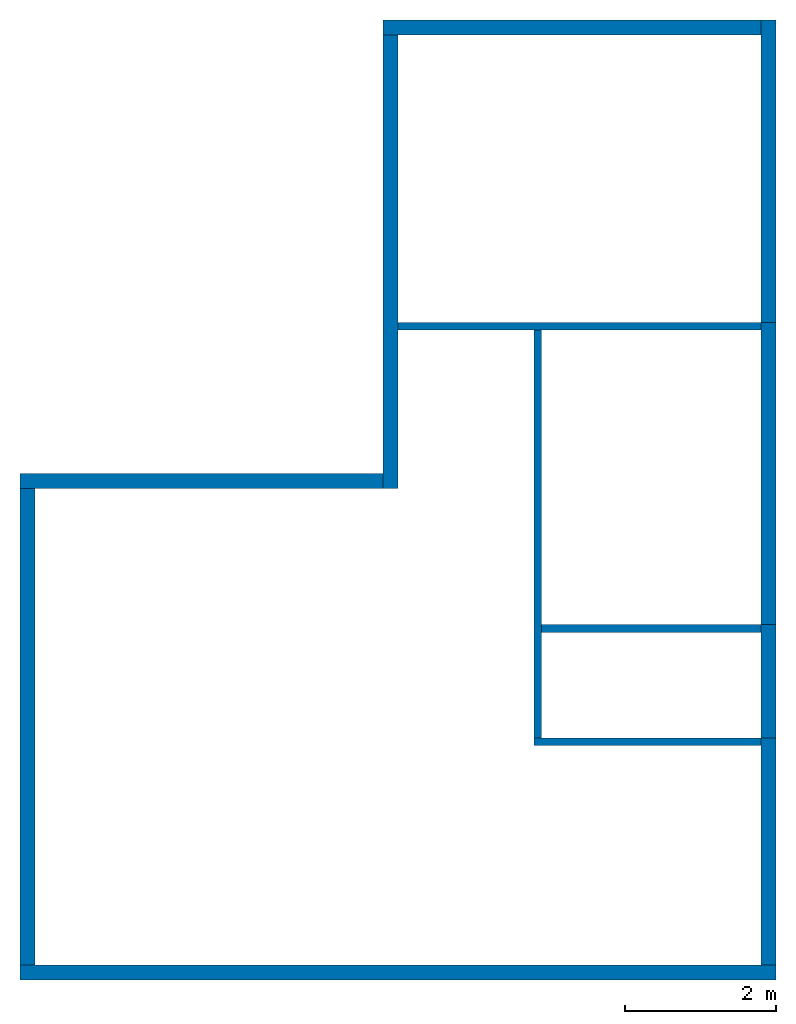
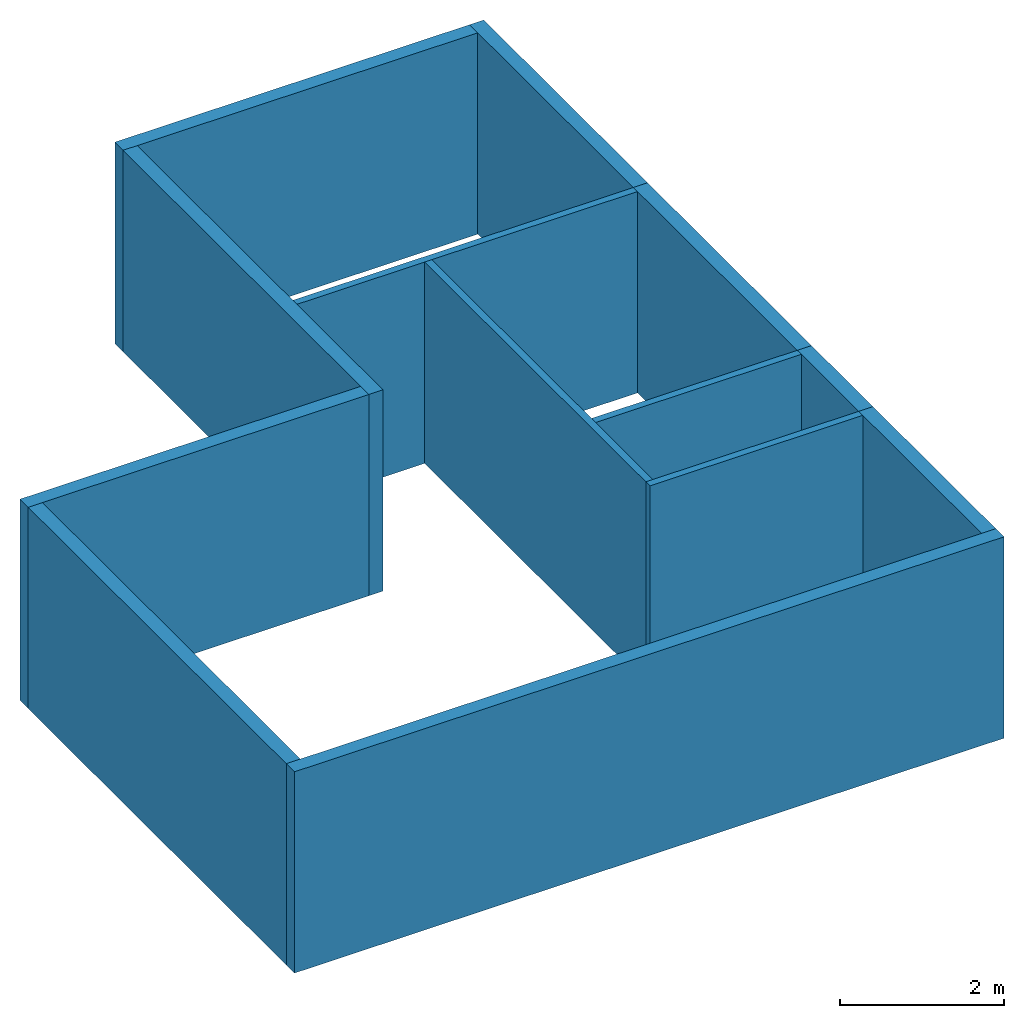
# One storey: 13 walls.
"""IFC4 building model written with IfcOpenShell, lengths in metres."""

import ifcopenshell
import ifcopenshell.guid

model = None  # the IFC model being written
_history = None  # IfcOwnerHistory: only IFC2X3 demands one
_inside = {}  # id of a spatial element -> (the spatial element, [elements in it])
_under = {}  # id of a project, library or spatial element -> (it, [spatial elements below it])
_declared = {}  # id of a project -> (the project, [libraries it declares])
_typed = {}  # id of a type object -> (the type object, [elements of that type])
_made_of = {}  # id of a material, layer set ... -> (it, [elements and type objects made of it])


def new_model(schema):
    """Start an empty IFC model of exactly this schema.

    Asked for "IFC4X3", IfcOpenShell would pick the latest addendum, in which some entities
    have other attributes; the version numbers below select the first issue.
    IFC2X3 requires an IfcOwnerHistory on every rooted entity: one is made here for all.
    """
    global model, _history
    if schema == "IFC4X3":
        model = ifcopenshell.file(schema_version=(4, 3, 0, 0))
    else:
        model = ifcopenshell.file(schema=schema)
    _inside.clear()
    _under.clear()
    _declared.clear()
    _typed.clear()
    _made_of.clear()
    _history = None
    if model.schema == "IFC2X3":
        org = make("IfcOrganization", Name="unknown")
        user = make(
            "IfcPersonAndOrganization",
            ThePerson=make("IfcPerson", FamilyName="unknown"),
            TheOrganization=org,
        )
        app = make(
            "IfcApplication",
            ApplicationDeveloper=org,
            Version="unknown",
            ApplicationFullName="unknown",
            ApplicationIdentifier="unknown",
        )
        _history = make(
            "IfcOwnerHistory",
            OwningUser=user,
            OwningApplication=app,
            ChangeAction="ADDED",
            CreationDate=0,
        )
    return model


def make(cls, **values):
    """One entity of the class cls with the attributes given. An attribute that is None is left unset."""
    return model.create_entity(
        cls, **{name: value for name, value in values.items() if value is not None}
    )


def entity(cls, *values):
    """Any entity or typed value of the class cls, its attributes in the order of the schema. None: left unset."""
    e = model.create_entity(cls)
    for i, value in enumerate(values):
        if value is not None:
            e[i] = value
    return e


def rooted(cls, **values):
    """An entity with a GlobalId (a new one), such as an element, a storey or a relation."""
    return make(cls, GlobalId=ifcopenshell.guid.new(), OwnerHistory=_history, **values)


def si_unit(unit_type, name, prefix=None):
    """IfcSIUnit, for example si_unit("LENGTHUNIT", "METRE", prefix="MILLI")."""
    return make("IfcSIUnit", UnitType=unit_type, Prefix=prefix, Name=name)


def converted_unit(unit_type, name, factor, base, dimensions=None, offset=None):
    """IfcConversionBasedUnit, such as the inch: factor (a typed value) times the base unit."""
    return make(
        "IfcConversionBasedUnit"
        if offset is None
        else "IfcConversionBasedUnitWithOffset",
        ConversionOffset=offset,
        Dimensions=None
        if dimensions is None
        else entity("IfcDimensionalExponents", *dimensions),
        UnitType=unit_type,
        Name=name,
        ConversionFactor=make(
            "IfcMeasureWithUnit", ValueComponent=factor, UnitComponent=base
        ),
    )


def assignment(units):
    """IfcUnitAssignment: the units of a project."""
    return None if units is None else make("IfcUnitAssignment", Units=units)


def point(xyz):
    """IfcCartesianPoint."""
    return None if xyz is None else make("IfcCartesianPoint", Coordinates=xyz)


def direction(xyz):
    """IfcDirection."""
    return None if xyz is None else make("IfcDirection", DirectionRatios=xyz)


def frame(location, z_axis=None, x_axis=None):
    """IfcAxis2Placement3D, a coordinate frame: its origin and axes. An axis left out is left unset."""
    return make(
        "IfcAxis2Placement3D",
        Location=point(location),
        Axis=direction(z_axis),
        RefDirection=direction(x_axis),
    )


def frame_2d(location, x_axis=None):
    """IfcAxis2Placement2D, a coordinate frame in the plane: its origin and x axis."""
    return make(
        "IfcAxis2Placement2D", Location=point(location), RefDirection=direction(x_axis)
    )


def origin_with_axes():
    """The frame at (0, 0, 0) with the z axis (0, 0, 1) and the x axis (1, 0, 0) written out."""
    return frame((0.0, 0.0, 0.0), z_axis=(0.0, 0.0, 1.0), x_axis=(1.0, 0.0, 0.0))


def origin_2d_with_axis():
    """The frame at (0, 0) in the plane with the x axis (1, 0) written out."""
    return frame_2d((0.0, 0.0), x_axis=(1.0, 0.0))


def place(relative_to, where):
    """IfcLocalPlacement: puts the frame where relative to a parent placement (None: the world)."""
    return make(
        "IfcLocalPlacement", PlacementRelTo=relative_to, RelativePlacement=where
    )


def context(
    kind, dimensions, precision=None, world=None, true_north=None, identifier=None
):
    """IfcGeometricRepresentationContext, for example the 3D "Model" context."""
    return make(
        "IfcGeometricRepresentationContext",
        ContextIdentifier=identifier,
        ContextType=kind,
        CoordinateSpaceDimension=dimensions,
        Precision=precision,
        WorldCoordinateSystem=world,
        TrueNorth=true_north,
    )


def subcontext(parent, identifier, kind, view, scale=None):
    """IfcGeometricRepresentationSubContext, for example "Body" below "Model"."""
    return make(
        "IfcGeometricRepresentationSubContext",
        ContextIdentifier=identifier,
        ContextType=kind,
        ParentContext=parent,
        TargetScale=scale,
        TargetView=view,
    )


def project(units=None, contexts=None):
    """IfcProject with its units and contexts."""
    return rooted(
        "IfcProject",
        Name="project",
        RepresentationContexts=contexts,
        UnitsInContext=assignment(units),
    )


def spatial(cls, under=None, at=None, **own):
    """A site, building, storey or space (cls), placed at a placement, below another one or the project."""
    s = rooted(cls, ObjectPlacement=at, **own)
    if under is not None:
        _under.setdefault(under.id(), (under, []))[1].append(s)
    return s


def point_list(points):
    """IfcCartesianPointList2D or 3D."""
    cls = (
        "IfcCartesianPointList2D" if len(points[0]) == 2 else "IfcCartesianPointList3D"
    )
    return make(cls, CoordList=points)


def indexed_curve(points, segments=None, self_intersect=None):
    """IfcIndexedPolyCurve: lines and arcs through numbered points (the first is 1)."""
    return make(
        "IfcIndexedPolyCurve",
        Points=point_list(points),
        Segments=segments,
        SelfIntersect=self_intersect,
    )


def outline(outer, holes=None, kind="AREA"):
    """IfcArbitraryClosedProfileDef: a profile drawn as a closed curve; with holes, ...WithVoids."""
    if holes is None:
        return make("IfcArbitraryClosedProfileDef", ProfileType=kind, OuterCurve=outer)
    return make(
        "IfcArbitraryProfileDefWithVoids",
        ProfileType=kind,
        OuterCurve=outer,
        InnerCurves=holes,
    )


def extrude(swept, where, along, depth):
    """IfcExtrudedAreaSolid: the profile swept, set in the frame where, extruded along a direction by depth."""
    return make(
        "IfcExtrudedAreaSolid",
        SweptArea=swept,
        Position=where,
        ExtrudedDirection=direction(along),
        Depth=depth,
    )


def shape(context_of_items, identifier, shape_type, items):
    """IfcShapeRepresentation: the items that make up one representation, for example the "Body"."""
    return make(
        "IfcShapeRepresentation",
        ContextOfItems=context_of_items,
        RepresentationIdentifier=identifier,
        RepresentationType=shape_type,
        Items=items,
    )


def material(Name=None, Category=None):
    """IfcMaterial."""
    return make("IfcMaterial", Name=Name, Category=Category)


def layer(
    of_material, thickness, ventilated=None, Name=None, Category=None, Priority=None
):
    """IfcMaterialLayer: one layer of a wall or slab, of a material (None: an air gap)."""
    return make(
        "IfcMaterialLayer",
        Material=of_material,
        LayerThickness=thickness,
        IsVentilated=ventilated,
        Name=Name,
        Category=Category,
        Priority=Priority,
    )


def layer_set(layers, Name=None):
    """IfcMaterialLayerSet."""
    return make("IfcMaterialLayerSet", MaterialLayers=layers, LayerSetName=Name)


def layer_usage(for_layer_set, set_direction, sense, offset, extent=None):
    """IfcMaterialLayerSetUsage: how a layer set lies in its element."""
    return make(
        "IfcMaterialLayerSetUsage",
        ForLayerSet=for_layer_set,
        LayerSetDirection=set_direction,
        DirectionSense=sense,
        OffsetFromReferenceLine=offset,
        ReferenceExtent=extent,
    )


def made_of(thing, what):
    """Note that an element or type object is made of a material, layer set ...; save() writes the relation."""
    if what is not None:
        _made_of.setdefault(what.id(), (what, []))[1].append(thing)
    return thing


def type_object(cls, material=None, **own):
    """A type object (cls), such as IfcWallType, which elements share."""
    return made_of(rooted(cls, **own), material)


def element(
    cls,
    number,
    at=None,
    inside=None,
    cuts=None,
    type_object=None,
    material=None,
    context=None,
    identifier="Body",
    shape_type=None,
    held_by="IfcProductDefinitionShape",
    body=None,
    shapes=None,
    **own,
):
    """One element of the class cls, such as IfcWall. Its Tag is "e" and its number.

    at: its placement. inside: the storey or other place that contains it. cuts: it is an
    opening in that element (IfcRelVoidsElement). A single representation is given by context,
    identifier, shape_type and body (its items); several are given by shapes. held_by: the class
    of the entity that holds the representations. save() writes the other relations.
    """
    e = rooted(cls, Tag="e%d" % number, ObjectPlacement=at, **own)
    if body is not None:
        shapes = [shape(context, identifier, shape_type, body)]
    if shapes is not None:
        e.Representation = make(held_by, Representations=shapes)
    if inside is not None:
        _inside.setdefault(inside.id(), (inside, []))[1].append(e)
    if cuts is not None:
        rooted(
            "IfcRelVoidsElement", RelatingBuildingElement=cuts, RelatedOpeningElement=e
        )
    if type_object is not None:
        _typed.setdefault(type_object.id(), (type_object, []))[1].append(e)
    return made_of(e, material)


def aggregate(whole, parts):
    """IfcRelAggregates: a whole, such as a stair, and the parts it consists of."""
    return rooted("IfcRelAggregates", RelatingObject=whole, RelatedObjects=parts)


def save(model, path):
    """Write the relations noted so far, then the file.

    IfcRelAggregates (storeys below a building ...), IfcRelContainedInSpatialStructure (elements
    in a storey), IfcRelDefinesByType, IfcRelAssociatesMaterial and IfcRelDeclares: one each for
    every whole, place, type object, material and project.
    """
    for whole, parts in _under.values():
        aggregate(whole, parts)
    for where, things in _inside.values():
        rooted(
            "IfcRelContainedInSpatialStructure",
            RelatedElements=things,
            RelatingStructure=where,
        )
    for kind, things in _typed.values():
        rooted("IfcRelDefinesByType", RelatedObjects=things, RelatingType=kind)
    for what, things in _made_of.values():
        rooted("IfcRelAssociatesMaterial", RelatedObjects=things, RelatingMaterial=what)
    for by, libraries in _declared.values():
        rooted("IfcRelDeclares", RelatingContext=by, RelatedDefinitions=libraries)
    model.write(path)


model = new_model("IFC4")

# Units and contexts
model_context = context("Model", 3, precision=1e-05, world=origin_with_axes())
plan_context = context("Plan", 2, precision=1e-05, world=origin_2d_with_axis())
body_context = subcontext(model_context, "Body", "Model", "MODEL_VIEW")
ifc_project = project(units=[converted_unit("PLANEANGLEUNIT", "degree", entity("IfcReal", 0.0174532925199433), si_unit("PLANEANGLEUNIT", "RADIAN"), dimensions=[0, 0, 0, 0, 0, 0, 0]), si_unit("AREAUNIT", "SQUARE_METRE"), si_unit("VOLUMEUNIT", "CUBIC_METRE"), si_unit("LENGTHUNIT", "METRE")], contexts=[model_context, plan_context])

# Site, building, storey
site_placement = place(None, origin_with_axes())
site = spatial("IfcSite", under=ifc_project, at=site_placement)
building_placement = place(site_placement, origin_with_axes())
building = spatial("IfcBuilding", under=site, at=building_placement, Name="Building")
storey_placement = place(building_placement, origin_with_axes())
storey = spatial("IfcBuildingStorey", under=building, at=storey_placement, Name="Storey")

# Walls
ifc_material = material()
ifc_layer_1 = layer(ifc_material, 0.1)
ifc_layer_set_1 = layer_set([ifc_layer_1])
ifc_layer_usage_1 = layer_usage(ifc_layer_set_1, "AXIS2", "POSITIVE", 0.0)
wall_type_1 = type_object("IfcWallType", Name="WAL100", PredefinedType="NOTDEFINED", material=ifc_layer_set_1)
wall_1_placement = place(storey_placement, frame((9.80000114440918, 3.20000004768372, 0.0), z_axis=(0.0, 0.0, 1.0), x_axis=(-0.999999999999924, 3.89414367418765e-07, 0.0)))
element("IfcWall", 1, at=wall_1_placement, inside=storey, type_object=wall_type_1, material=ifc_layer_usage_1, Name="Wall", context=body_context, shape_type="SweptSolid", body=[
    extrude(outline(indexed_curve([(0.0, 0.0), (0.0, 0.1), (3.00000000000024, 0.1), (3.00000000000024, 0.0), (0.0, 0.0)], self_intersect=False)), origin_with_axes(), (0.0, 0.0, 1.0), 3.0),
])
ifc_layer_usage_2 = layer_usage(ifc_layer_set_1, "AXIS2", "POSITIVE", 0.0)
wall_2_placement = place(storey_placement, frame((9.8000020980835, 4.69999980926514, 0.0), z_axis=(0.0, 0.0, 1.0), x_axis=(-0.999999999999924, 3.89414367418765e-07, 0.0)))
element("IfcWall", 2, at=wall_2_placement, inside=storey, type_object=wall_type_1, material=ifc_layer_usage_2, Name="Wall", context=body_context, shape_type="SweptSolid", body=[
    extrude(outline(indexed_curve([(0.0, 0.0), (0.0, 0.1), (2.89999964483867, 0.1), (2.89999964483867, 0.0), (0.0, 0.0)], self_intersect=False)), origin_with_axes(), (0.0, 0.0, 1.0), 3.0),
])
ifc_layer_usage_3 = layer_usage(ifc_layer_set_1, "AXIS2", "POSITIVE", 0.0)
wall_3_placement = place(storey_placement, frame((9.80000495910645, 8.69999980926514, 0.0), z_axis=(0.0, 0.0, 1.0), x_axis=(-0.999999999999924, 3.89414367418765e-07, 0.0)))
element("IfcWall", 3, at=wall_3_placement, inside=storey, type_object=wall_type_1, material=ifc_layer_usage_3, Name="Wall", context=body_context, shape_type="SweptSolid", body=[
    extrude(outline(indexed_curve([(0.0, 0.0), (0.0, 0.1), (4.79999830722817, 0.1), (4.79999830722817, 0.0), (0.0, 0.0)], self_intersect=False)), origin_with_axes(), (0.0, 0.0, 1.0), 3.0),
])
ifc_layer_usage_4 = layer_usage(ifc_layer_set_1, "AXIS2", "POSITIVE", 0.0)
wall_4_placement = place(storey_placement, frame((6.80000448226929, 8.60000038146973, 0.0), z_axis=(0.0, 0.0, 1.0), x_axis=(-6.39757843145941e-07, -0.999999999999795, 0.0)))
element("IfcWall", 4, at=wall_4_placement, inside=storey, type_object=wall_type_1, material=ifc_layer_usage_4, Name="Wall", context=body_context, shape_type="SweptSolid", body=[
    extrude(outline(indexed_curve([(0.0, 0.0), (0.0, 0.1), (5.39999910284067, 0.1), (5.39999910284067, 0.0), (0.0, 0.0)], self_intersect=False)), origin_with_axes(), (0.0, 0.0, 1.0), 3.0),
])
ifc_layer_2 = layer(ifc_material, 0.2)
ifc_layer_set_2 = layer_set([ifc_layer_2])
ifc_layer_usage_5 = layer_usage(ifc_layer_set_2, "AXIS2", "POSITIVE", 0.0)
wall_type_2 = type_object("IfcWallType", Name="WAL200", PredefinedType="NOTDEFINED", material=ifc_layer_set_2)
wall_5_placement = place(storey_placement, origin_with_axes())
element("IfcWall", 5, at=wall_5_placement, inside=storey, type_object=wall_type_2, material=ifc_layer_usage_5, Name="Wall", context=body_context, shape_type="SweptSolid", body=[
    extrude(outline(indexed_curve([(0.0, 0.0), (0.0, 0.2), (10.0, 0.2), (10.0, 0.0), (0.0, 0.0)], self_intersect=False)), origin_with_axes(), (0.0, 0.0, 1.0), 3.0),
])
ifc_layer_usage_6 = layer_usage(ifc_layer_set_2, "AXIS2", "POSITIVE", 0.0)
wall_6_placement = place(storey_placement, frame((10.0, 0.200000002980232, 0.0), z_axis=(0.0, 0.0, 1.0), x_axis=(7.54979012640431e-08, 0.999999999999997, 0.0)))
element("IfcWall", 6, at=wall_6_placement, inside=storey, type_object=wall_type_2, material=ifc_layer_usage_6, Name="Wall", context=body_context, shape_type="SweptSolid", body=[
    extrude(outline(indexed_curve([(0.0, 0.0), (0.0, 0.2), (3.00000000000015, 0.2), (3.00000000000015, 0.0), (0.0, 0.0)], self_intersect=False)), origin_with_axes(), (0.0, 0.0, 1.0), 3.0),
])
ifc_layer_usage_7 = layer_usage(ifc_layer_set_2, "AXIS2", "POSITIVE", 0.0)
wall_7_placement = place(storey_placement, frame((9.8000020980835, 4.69999980926514, 0.0), z_axis=(0.0, 0.0, 1.0), x_axis=(-6.39757843145941e-07, -0.999999999999795, 0.0)))
element("IfcWall", 7, at=wall_7_placement, inside=storey, type_object=wall_type_2, material=ifc_layer_usage_7, Name="Wall", context=body_context, shape_type="SweptSolid", body=[
    extrude(outline(indexed_curve([(0.0, 0.0), (0.0, 0.2), (1.49999976158171, 0.2), (1.49999976158171, 0.0), (0.0, 0.0)], self_intersect=False)), origin_with_axes(), (0.0, 0.0, 1.0), 3.0),
])
ifc_layer_usage_8 = layer_usage(ifc_layer_set_2, "AXIS2", "POSITIVE", 0.0)
wall_8_placement = place(storey_placement, frame((9.80000495910645, 8.69999980926514, 0.0), z_axis=(0.0, 0.0, 1.0), x_axis=(-6.39757843145941e-07, -0.999999999999795, 0.0)))
element("IfcWall", 8, at=wall_8_placement, inside=storey, type_object=wall_type_2, material=ifc_layer_usage_8, Name="Wall", context=body_context, shape_type="SweptSolid", body=[
    extrude(outline(indexed_curve([(0.0, 0.0), (0.0, 0.2), (4.00000000000102, 0.2), (4.00000000000102, 0.0), (0.0, 0.0)], self_intersect=False)), origin_with_axes(), (0.0, 0.0, 1.0), 3.0),
])
ifc_layer_usage_9 = layer_usage(ifc_layer_set_2, "AXIS2", "POSITIVE", 0.0)
wall_9_placement = place(storey_placement, frame((10.0000047683716, 8.69999980926514, 0.0), z_axis=(0.0, 0.0, 1.0), x_axis=(5.52335052361657e-07, 0.999999999999847, 0.0)))
element("IfcWall", 9, at=wall_9_placement, inside=storey, type_object=wall_type_2, material=ifc_layer_usage_9, Name="Wall", context=body_context, shape_type="SweptSolid", body=[
    extrude(outline(indexed_curve([(0.0, 0.0), (0.0, 0.2), (4.0, 0.2), (4.0, 0.0), (0.0, 0.0)], self_intersect=False)), origin_with_axes(), (0.0, 0.0, 1.0), 3.0),
])
ifc_layer_usage_10 = layer_usage(ifc_layer_set_2, "AXIS2", "POSITIVE", 0.0)
wall_10_placement = place(storey_placement, frame((9.80000782012939, 12.6999998092651, 0.0), z_axis=(0.0, 0.0, 1.0), x_axis=(-0.999999999999924, 3.89414367418765e-07, 0.0)))
element("IfcWall", 10, at=wall_10_placement, inside=storey, type_object=wall_type_2, material=ifc_layer_usage_10, Name="Wall", context=body_context, shape_type="SweptSolid", body=[
    extrude(outline(indexed_curve([(0.0, 0.0), (0.0, 0.2), (5.00000000000036, 0.2), (5.00000000000036, 0.0), (0.0, 0.0)], self_intersect=False)), origin_with_axes(), (0.0, 0.0, 1.0), 3.0),
])
ifc_layer_usage_11 = layer_usage(ifc_layer_set_2, "AXIS2", "POSITIVE", 0.0)
wall_11_placement = place(storey_placement, frame((4.80000782012939, 12.5000019073486, 0.0), z_axis=(0.0, 0.0, 1.0), x_axis=(-4.01339264044477e-07, -0.99999999999992, 0.0)))
element("IfcWall", 11, at=wall_11_placement, inside=storey, type_object=wall_type_2, material=ifc_layer_usage_11, Name="Wall", context=body_context, shape_type="SweptSolid", body=[
    extrude(outline(indexed_curve([(0.0, 0.0), (0.0, 0.2), (6.0000000000003, 0.2), (6.0000000000003, 0.0), (0.0, 0.0)], self_intersect=False)), origin_with_axes(), (0.0, 0.0, 1.0), 3.0),
])
ifc_layer_usage_12 = layer_usage(ifc_layer_set_2, "AXIS2", "POSITIVE", 0.0)
wall_12_placement = place(storey_placement, frame((3.814697265625e-06, 6.50000476837158, 0.0), z_axis=(0.0, 0.0, 1.0), x_axis=(0.999999999999744, -7.15255737304505e-07, 0.0)))
element("IfcWall", 12, at=wall_12_placement, inside=storey, type_object=wall_type_2, material=ifc_layer_usage_12, Name="Wall", context=body_context, shape_type="SweptSolid", body=[
    extrude(outline(indexed_curve([(0.0, 0.0), (0.0, 0.2), (4.80000208218963, 0.2), (4.80000208218963, 0.0), (0.0, 0.0)], self_intersect=False)), origin_with_axes(), (0.0, 0.0, 1.0), 3.0),
])
ifc_layer_usage_13 = layer_usage(ifc_layer_set_2, "AXIS2", "POSITIVE", 0.0)
wall_13_placement = place(storey_placement, frame((3.814697265625e-06, 6.50000476837158, 0.0), z_axis=(0.0, 0.0, 1.0), x_axis=(-7.58967132696634e-07, -0.999999999999712, 0.0)))
element("IfcWall", 13, at=wall_13_placement, inside=storey, type_object=wall_type_2, material=ifc_layer_usage_13, Name="Wall", context=body_context, shape_type="SweptSolid", body=[
    extrude(outline(indexed_curve([(0.0, 0.0), (0.0, 0.2), (6.3000041295611, 0.2), (6.3000041295611, 0.0), (0.0, 0.0)], self_intersect=False)), origin_with_axes(), (0.0, 0.0, 1.0), 3.0),
])

save(model, "model.ifc")
